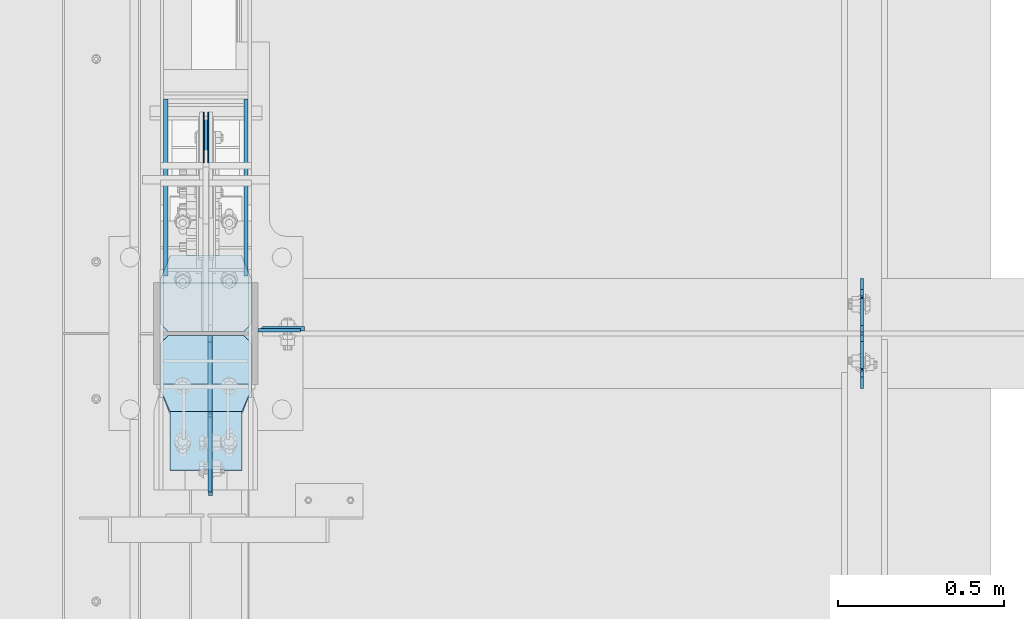
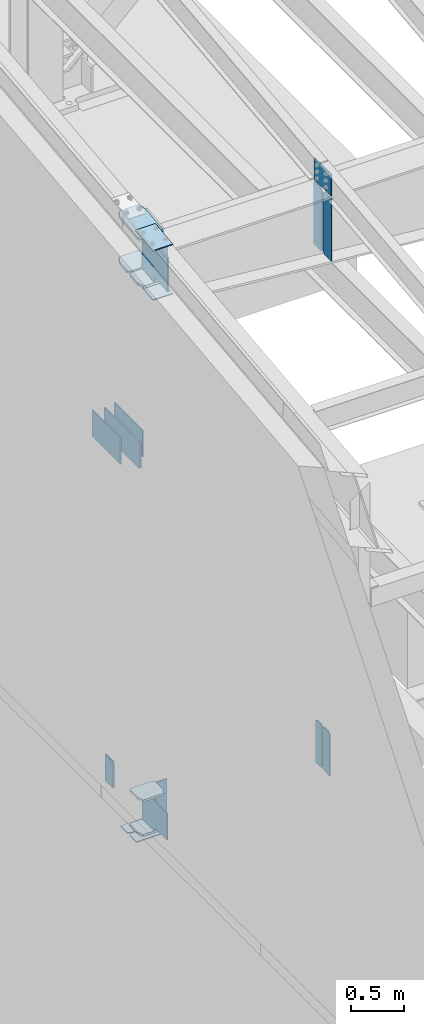
# One storey, part 990 of 1179: 23 plates, 4 elements without a shape of their own.
"""IFC2X3 building model written with IfcOpenShell, lengths in millimetres."""

from ifc_helpers import new_model, si_unit, frame, origin_with_axes, place, context, subcontext, project, spatial, faceted_brep, material, type_object, element, aggregate, save


model = new_model("IFC2X3")

# Units and contexts
model_context = context("Model", 3, precision=1e-05, world=origin_with_axes())
body_context = subcontext(model_context, "Body", "Model", "MODEL_VIEW")
ifc_project = project(units=[si_unit("LENGTHUNIT", "METRE", prefix="MILLI"), si_unit("AREAUNIT", "SQUARE_METRE"), si_unit("VOLUMEUNIT", "CUBIC_METRE"), si_unit("MASSUNIT", "GRAM", prefix="KILO"), si_unit("TIMEUNIT", "SECOND"), si_unit("PLANEANGLEUNIT", "RADIAN"), si_unit("SOLIDANGLEUNIT", "STERADIAN"), si_unit("THERMODYNAMICTEMPERATUREUNIT", "DEGREE_CELSIUS"), si_unit("LUMINOUSINTENSITYUNIT", "LUMEN")], contexts=[model_context])

# Site, building, storey
site_placement = place(None, origin_with_axes())
site = spatial("IfcSite", under=ifc_project, at=site_placement, CompositionType="ELEMENT")
building_placement = place(site_placement, origin_with_axes())
building = spatial("IfcBuilding", under=site, at=building_placement, Name="Undefined", CompositionType="ELEMENT")
storey_placement = place(building_placement, origin_with_axes())
storey = spatial("IfcBuildingStorey", under=building, at=storey_placement, Name="Undefined", CompositionType="ELEMENT", Elevation=0.0)

# Assembly, plate
assembly_1_placement = place(storey_placement, origin_with_axes())
assembly_1 = element("IfcElementAssembly", 1, at=assembly_1_placement, inside=storey, Name="COLUMN", AssemblyPlace="NOTDEFINED", PredefinedType="RIGID_FRAME")
ifc_material_1 = material(Name="STEEL/A36")
plate_type_1 = type_object("IfcPlateType", PredefinedType="NOTDEFINED")
plate_1_placement = place(assembly_1_placement, frame((588.962500000001, 11490.325, 4064.0), z_axis=(1.0, 0.0, 0.0), x_axis=(0.0, 0.0, -1.0)))
plate_1 = element("IfcPlate", 2, at=plate_1_placement, type_object=plate_type_1, material=ifc_material_1, Name="PLATE", context=body_context, shape_type="Brep", body=[
    faceted_brep([(0.0, -4.76249999999709, 0.0), (0.0, -4.76249999999709, 127.0), (0.0, 4.76249999999709, 127.0), (0.0, 4.76249999999709, 0.0), (381.0, -4.76249999999709, 127.0), (381.0, 4.76249999999709, 127.0), (381.0, -4.76249999999999, 8.66293703438714e-11), (381.0, 4.76249999999999, 8.66293703438714e-11)], [[[0, 1, 2, 3]], [[1, 4, 5, 2]], [[4, 6, 7, 5]], [[6, 0, 3, 7]], [[5, 7, 3, 2]], [[6, 4, 1, 0]]]),
])

# Assembly, plates
assembly_2_placement = place(storey_placement, origin_with_axes())
assembly_2 = element("IfcElementAssembly", 3, at=assembly_2_placement, inside=storey, Name="BEAM", AssemblyPlace="NOTDEFINED", PredefinedType="RIGID_FRAME")
plate_2_placement = place(assembly_2_placement, frame((2405.06192754092, 11476.0374998857, 3586.1625), z_axis=(0.0, 0.0, 1.0), x_axis=(0.0, -1.0, 0.0)))
plate_2 = element("IfcPlate", 4, at=plate_2_placement, type_object=plate_type_1, material=ifc_material_1, Name="PLATE", context=body_context, shape_type="Brep", body=[
    faceted_brep([(100.012500000004, -4.76250000000073, 498.475), (100.012499999999, -4.76249999999982, 496.887499809265), (100.012499999999, 4.76249999999982, 496.887499809265), (100.012500000004, 4.76250000000073, 498.475), (100.979229922586, -4.76249999999982, 492.027420291219), (100.979229922586, 4.76249999999982, 492.027420291219), (103.732243823064, -4.76249999999982, 487.907243823066), (103.732243823064, 4.76249999999982, 487.907243823066), (107.852420291218, -4.76249999999982, 485.154229922588), (107.852420291218, 4.76249999999982, 485.154229922588), (112.712499809264, -4.76249999999982, 484.1875), (112.712499809264, 4.76249999999982, 484.1875), (127.000006866454, -4.76249999999982, 484.1875), (127.000004873051, 4.76249999999982, 484.1875), (0.0, -4.76250000000073, 479.425006866455), (19.0499992370605, -4.76250000000073, 498.475006103516), (19.0499992370605, 4.76250000000073, 498.475006103516), (0.0, 4.76250000000073, 479.425006866455), (0.0, -4.76250000000073, 19.0499992370605), (0.0, 4.76250000000073, 19.0499992370605), (19.0499992370605, -4.76250000000073, 0.0), (19.0499992370605, 4.76250000000073, 0.0), (127.0, -4.76250000000073, 0.0), (127.0, 4.76250000000073, 0.0)], [[[0, 1, 2, 3]], [[4, 5, 2, 1]], [[6, 7, 5, 4]], [[8, 9, 7, 6]], [[10, 11, 9, 8]], [[12, 13, 11, 10]], [[14, 15, 16, 17]], [[18, 14, 17, 19]], [[20, 18, 19, 21]], [[22, 20, 21, 23]], [[8, 6, 4, 1, 0, 15, 14, 18, 20, 22, 12, 10]], [[16, 15, 0, 3]], [[23, 21, 19, 17, 16, 3, 2, 5, 7, 9, 11, 13]], [[22, 23, 13, 12]]]),
])
plate_3_placement = place(assembly_2_placement, frame((2405.06185359955, 11485.5625, 3586.1625), z_axis=(0.0, 0.0, 1.0), x_axis=(0.0, 1.0, 0.0)))
plate_3 = element("IfcPlate", 5, at=plate_3_placement, type_object=plate_type_1, material=ifc_material_1, Name="PLATE", context=body_context, shape_type="Brep", body=[
    faceted_brep([(100.012500000004, -4.76250000000073, 498.475), (100.012499999999, -4.76249999999982, 496.887499809265), (100.012499999999, 4.76249999999982, 496.887499809265), (100.012500000004, 4.76250000000073, 498.475), (100.979229922586, -4.76249999999982, 492.027420291219), (100.979229922586, 4.76249999999982, 492.027420291219), (103.732243823064, -4.76249999999982, 487.907243823066), (103.732243823064, 4.76249999999982, 487.907243823066), (107.852420291218, -4.76249999999982, 485.154229922588), (107.852420291218, 4.76249999999982, 485.154229922588), (112.712499809264, -4.76249999999982, 484.1875), (112.712499809264, 4.76249999999982, 484.1875), (127.000006866454, -4.76249999999982, 484.1875), (127.000004873051, 4.76249999999982, 484.1875), (0.0, -4.76250000000073, 479.425006866455), (19.0499992370605, -4.76250000000073, 498.475006103516), (19.0499992370605, 4.76250000000073, 498.475006103516), (0.0, 4.76250000000073, 479.425006866455), (0.0, -4.76250000000073, 19.0499992370605), (0.0, 4.76250000000073, 19.0499992370605), (19.0499992370605, -4.76250000000073, 0.0), (19.0499992370605, 4.76250000000073, 0.0), (127.0, -4.76250000000073, 0.0), (127.0, 4.76250000000073, 0.0)], [[[0, 1, 2, 3]], [[4, 5, 2, 1]], [[6, 7, 5, 4]], [[8, 9, 7, 6]], [[10, 11, 9, 8]], [[12, 13, 11, 10]], [[14, 15, 16, 17]], [[18, 14, 17, 19]], [[20, 18, 19, 21]], [[22, 20, 21, 23]], [[8, 6, 4, 1, 0, 15, 14, 18, 20, 22, 12, 10]], [[16, 15, 0, 3]], [[23, 21, 19, 17, 16, 3, 2, 5, 7, 9, 11, 13]], [[22, 23, 13, 12]]]),
])
aggregate(assembly_2, [plate_2, plate_3])

assembly_3_placement = place(storey_placement, origin_with_axes())
assembly_3 = element("IfcElementAssembly", 6, at=assembly_3_placement, inside=storey, Name="RAFTER BEAM", AssemblyPlace="NOTDEFINED", PredefinedType="RIGID_FRAME")
plate_type_2 = type_object("IfcPlateType", PredefinedType="NOTDEFINED")
plate_4_placement = place(assembly_3_placement, frame((2405.0625, 11645.9093353251, 10228.28385672), z_axis=(0.0, 0.0, -1.0), x_axis=(0.0, -1.0, 0.0)))
plate_4 = element("IfcPlate", 7, at=plate_4_placement, type_object=plate_type_2, material=ifc_material_1, Name="PLATE", context=body_context, shape_type="Brep", body=[
    faceted_brep([(0.0, -4.76249999999709, 0.0), (-1.6992817108985e-06, -4.76249999999982, 719.900724495752), (-1.6992817108985e-06, 4.76249999999982, 719.900724495752), (0.0, 4.76249999999709, 0.0), (131.762498682183, -4.76249999999982, 719.900724815363), (131.762498682183, 4.76249999999982, 719.900724815363), (157.162498360671, -4.76249999999982, 694.500725258442), (157.162498360671, 4.76249999999982, 694.500725258442), (157.162499942613, -4.76250000000073, 25.3999996182793), (157.162499942613, 4.76250000000073, 25.3999996182793), (131.762500381465, -4.76250000000073, -2.09183781407773e-10), (131.762500381465, 4.76250000000073, -2.09183781407773e-10)], [[[0, 1, 2, 3]], [[1, 4, 5, 2]], [[4, 6, 7, 5]], [[6, 8, 9, 7]], [[8, 10, 11, 9]], [[10, 0, 3, 11]], [[5, 7, 9, 11, 3, 2]], [[10, 8, 6, 4, 1, 0]]]),
])
plate_5_placement = place(assembly_3_placement, frame((2405.0625, 11315.7093353614, 10228.28385672), z_axis=(0.0, 0.0, -1.0), x_axis=(0.0, 1.0, 0.0)))
plate_5 = element("IfcPlate", 8, at=plate_5_placement, type_object=plate_type_2, material=ifc_material_1, Name="PLATE", context=body_context, shape_type="Brep", body=[
    faceted_brep([(0.0, -4.76249999999709, 0.0), (-1.6992817108985e-06, -4.76249999999982, 719.900724495752), (-1.6992817108985e-06, 4.76249999999982, 719.900724495752), (0.0, 4.76249999999709, 0.0), (131.762498682183, -4.76249999999982, 719.900724815363), (131.762498682183, 4.76249999999982, 719.900724815363), (157.162498360671, -4.76249999999982, 694.500725258442), (157.162498360671, 4.76249999999982, 694.500725258442), (157.162499942613, -4.76250000000073, 25.3999996182793), (157.162499942613, 4.76250000000073, 25.3999996182793), (131.762500381465, -4.76250000000073, -2.09183781407773e-10), (131.762500381465, 4.76250000000073, -2.09183781407773e-10)], [[[0, 1, 2, 3]], [[1, 4, 5, 2]], [[4, 6, 7, 5]], [[6, 8, 9, 7]], [[8, 10, 11, 9]], [[10, 0, 3, 11]], [[5, 7, 9, 11, 3, 2]], [[10, 8, 6, 4, 1, 0]]]),
])

# Plate
plate_type_3 = type_object("IfcPlateType", PredefinedType="NOTDEFINED")
plate_6_placement = place(assembly_1_placement, frame((588.962500000001, 11495.0968353614, 10213.99635672), z_axis=(0.0, 0.0, -1.0), x_axis=(1.0, 0.0, 0.0)))
plate_6 = element("IfcPlate", 9, at=plate_6_placement, type_object=plate_type_3, material=ifc_material_1, Name="PLATE", context=body_context, shape_type="Brep", body=[
    faceted_brep([(0.0, 6.34999999999854, 0.0), (12.7, -6.35000000000036, 0.0), (12.7, -6.35000000000036, 533.4), (0.0, 6.35000000000036, 533.4), (139.700000000001, -6.35000000000036, 533.4), (139.700000000001, 6.35000000000036, 533.4), (139.699999999997, -6.35000000000036, 0.0), (139.699999999997, 6.35000000000036, 0.0)], [[[0, 1, 2, 3]], [[4, 5, 3, 2]], [[4, 6, 7, 5]], [[7, 6, 1, 0]], [[5, 7, 0, 3]], [[6, 4, 2, 1]]]),
])

ifc_material_2 = material(Name="STEEL/A572-GR.50")
plate_type_4 = type_object("IfcPlateType", PredefinedType="NOTDEFINED")
plate_7_placement = place(assembly_1_placement, frame((431.799999999999, 12163.2501964861, 8013.7), z_axis=(0.0, 0.0, -1.0), x_axis=(0.0, -1.0, 0.0)))
plate_7 = element("IfcPlate", 10, at=plate_7_placement, type_object=plate_type_4, material=ifc_material_2, Name="PLATE", context=body_context, shape_type="Brep", body=[
    faceted_brep([(0.0, -9.52499999999964, 0.0), (0.0, -9.52499999999998, 304.799999999999), (0.0, 9.52499999999998, 304.799999999999), (0.0, 9.52499999999964, 0.0), (657.050197249024, -9.52499999999998, 304.799999999999), (657.050197249024, 9.52499999999998, 304.799999999999), (676.100196486084, -9.52499999999998, 285.750000762939), (676.100196486084, 9.52499999999998, 285.750000762939), (676.100196486084, -9.52499999999998, 19.0499992370605), (676.100196486084, 9.52499999999998, 19.0499992370605), (657.050197249024, -9.52499999999998, 0.0), (657.050197249024, 9.52499999999998, 0.0)], [[[0, 1, 2, 3]], [[1, 4, 5, 2]], [[4, 6, 7, 5]], [[6, 8, 9, 7]], [[8, 10, 11, 9]], [[10, 0, 3, 11]], [[5, 7, 9, 11, 3, 2]], [[10, 8, 6, 4, 1, 0]]]),
])

plate_type_5 = type_object("IfcPlateType", PredefinedType="NOTDEFINED")
plate_8_placement = place(assembly_1_placement, frame((295.274999999754, 11244.1139130949, 10503.1105351652), z_axis=(1.0, 0.0, 0.0), x_axis=(0.0, 0.993683229349742, 0.112221387039499)))
plate_8 = element("IfcPlate", 11, at=plate_8_placement, type_object=plate_type_5, material=ifc_material_2, Name="PLATE", context=body_context, shape_type="Brep", body=[
    faceted_brep([(404.009737741189, -14.2874999996602, 8.31619217933621e-11), (71.43750000002, -14.287499999984, 2.90469870378729e-11), (71.4375000000155, 14.2874999999949, 2.90469870378729e-11), (404.009737741166, 14.2875000003405, 8.31619217933621e-11), (477.034739267168, 14.2875000004005, 30.162500381568), (473.810043726306, -14.287499999602, 28.8305609300143), (477.034739268025, 14.2875000004024, 242.887499623284), (473.810043726306, -14.287499999602, 244.219439075195), (404.009737742264, 14.2875000003405, 273.05000000474), (404.00973774229, -14.2874999996602, 273.05000000474), (71.4375000016116, -14.2874999999858, 273.049999999798), (71.4375000016071, 14.2874999999967, 273.049999999798), (4.20644072178584, 14.2875000000058, 244.663552394444), (0.979329666730337, -14.2874999999967, 243.30099437618), (0.979329666730337, -14.2874999999967, 29.7490056281208), (4.20644072178584, 14.2875000000058, 28.3864476098539)], [[[0, 1, 2, 3]], [[0, 3, 4, 5]], [[5, 4, 6, 7]], [[8, 9, 7, 6]], [[10, 9, 8, 11]], [[10, 11, 12, 13]], [[1, 0, 5, 7, 9, 10, 13, 14]], [[2, 1, 14, 15]], [[11, 8, 6, 4, 3, 2, 15, 12]], [[14, 13, 12, 15]]]),
])

# Assembly, plates
assembly_4_placement = place(storey_placement, origin_with_axes())
assembly_4 = element("IfcElementAssembly", 12, at=assembly_4_placement, inside=storey, Name="BEAM", AssemblyPlace="NOTDEFINED", PredefinedType="RIGID_FRAME")
plate_type_6 = type_object("IfcPlateType", PredefinedType="NOTDEFINED")
plate_9_placement = place(assembly_4_placement, frame((438.943750000002, 12146.2984303375, 4044.95), z_axis=(0.0, 0.0, -1.0), x_axis=(0.0, -1.0, 0.0)))
plate_9 = element("IfcPlate", 13, at=plate_9_placement, type_object=plate_type_6, material=ifc_material_2, Name="PLATE", context=body_context, shape_type="Brep", body=[
    faceted_brep([(3.63797880709171e-12, -1.58750000000055, 1.81898940354586e-12), (-2.18278728425503e-11, -1.58750000000146, 304.8), (-2.18278728425503e-11, 1.58750000000146, 304.8), (-3.63797880709171e-12, 1.58750000000055, 0.0), (152.399999999994, -1.58750000000146, 304.8), (152.399999999994, 1.58750000000146, 304.8), (152.399999999994, -1.58750000000146, 0.0), (152.399999999994, 1.58750000000146, 0.0)], [[[0, 1, 2, 3]], [[1, 4, 5, 2]], [[4, 6, 7, 5]], [[6, 0, 3, 7]], [[5, 7, 3, 2]], [[6, 4, 1, 0]]]),
])
plate_10_placement = place(assembly_4_placement, frame((424.656250000002, 12146.2984303375, 4044.95), z_axis=(0.0, 0.0, -1.0), x_axis=(0.0, -1.0, 0.0)))
plate_10 = element("IfcPlate", 14, at=plate_10_placement, type_object=plate_type_6, material=ifc_material_2, Name="PLATE", context=body_context, shape_type="Brep", body=[
    faceted_brep([(3.63797880709171e-12, -1.58750000000055, 1.81898940354586e-12), (-2.18278728425503e-11, -1.58750000000146, 304.8), (-2.18278728425503e-11, 1.58750000000146, 304.8), (-3.63797880709171e-12, 1.58750000000055, 0.0), (152.399999999994, -1.58750000000146, 304.8), (152.399999999994, 1.58750000000146, 304.8), (152.399999999994, -1.58750000000146, 0.0), (152.399999999994, 1.58750000000146, 0.0)], [[[0, 1, 2, 3]], [[1, 4, 5, 2]], [[4, 6, 7, 5]], [[6, 0, 3, 7]], [[5, 7, 3, 2]], [[6, 4, 1, 0]]]),
])
aggregate(assembly_4, [plate_9, plate_10])

# Plate
plate_type_7 = type_object("IfcPlateType", PredefinedType="NOTDEFINED")
plate_11_placement = place(assembly_1_placement, frame((552.450000000001, 12185.4751974615, 8013.7), z_axis=(0.0, 0.0, -1.0), x_axis=(0.0, -1.0, 0.0)))
plate_11 = element("IfcPlate", 15, at=plate_11_placement, type_object=plate_type_7, material=ifc_material_2, Name="PLATE", context=body_context, shape_type="Brep", body=[
    faceted_brep([(0.0, -6.34999999999854, 0.0), (0.0, -6.34999999999854, 304.799999999999), (0.0, 6.34999999999854, 304.799999999999), (0.0, 6.34999999999854, 0.0), (531.637696486086, -6.34999999999854, 304.799999999999), (531.637696486086, 6.34999999999854, 304.799999999999), (531.637696486086, -6.34999999999854, 0.0), (531.637696486086, 6.34999999999854, 0.0)], [[[0, 1, 2, 3]], [[1, 4, 5, 2]], [[4, 6, 7, 5]], [[6, 0, 3, 7]], [[5, 7, 3, 2]], [[6, 4, 1, 0]]]),
])

plate_12_placement = place(assembly_1_placement, frame((311.150000000001, 12185.4751974615, 8013.7), z_axis=(0.0, 0.0, -1.0), x_axis=(0.0, -1.0, 0.0)))
plate_12 = element("IfcPlate", 16, at=plate_12_placement, type_object=plate_type_7, material=ifc_material_2, Name="PLATE", context=body_context, shape_type="Brep", body=[
    faceted_brep([(0.0, -6.34999999999854, 0.0), (0.0, -6.34999999999854, 304.799999999999), (0.0, 6.34999999999854, 304.799999999999), (0.0, 6.34999999999854, 0.0), (531.637696486086, -6.34999999999854, 304.799999999999), (531.637696486086, 6.34999999999854, 304.799999999999), (531.637696486086, -6.34999999999854, 0.0), (531.637696486086, 6.34999999999854, 0.0)], [[[0, 1, 2, 3]], [[1, 4, 5, 2]], [[4, 6, 7, 5]], [[6, 0, 3, 7]], [[5, 7, 3, 2]], [[6, 4, 1, 0]]]),
])

plate_type_8 = type_object("IfcPlateType", PredefinedType="NOTDEFINED")
plate_13_placement = place(assembly_1_placement, frame((295.275000000005, 11245.85, 3694.1125), z_axis=(1.0, 0.0, 0.0), x_axis=(0.0, 1.0, 0.0)))
plate_13 = element("IfcPlate", 17, at=plate_13_placement, type_object=plate_type_8, material=ifc_material_2, Name="PLATE", context=body_context, shape_type="Brep", body=[
    faceted_brep([(0.0, -11.1125000000002, 247.650000381473), (63.5, -11.1125000000002, 273.050000000003), (63.5, 11.1125000000002, 273.050000000003), (0.0, 11.1125000000002, 247.650000381473), (63.5, -11.1125000000002, 0.0), (0.0, -11.1125000000002, 25.3999996185303), (0.0, 11.1125000000002, 25.3999996185303), (63.5, 11.1125000000002, 0.0), (206.374999618529, -11.1125000000002, 0.0), (206.374999618529, 11.1125000000002, 0.0), (228.599999999999, -11.1125000000002, 22.2250003814697), (228.599999999999, 11.1125000000002, 22.2250003814697), (228.599999999999, -11.1125000000002, 250.824999618533), (228.599999999999, 11.1125000000002, 250.824999618533), (206.374999618529, -11.1125000000002, 273.050000000003), (206.374999618529, 11.1125000000002, 273.050000000003)], [[[0, 1, 2, 3]], [[4, 5, 6, 7]], [[8, 4, 7, 9]], [[10, 8, 9, 11]], [[12, 10, 11, 13]], [[14, 12, 13, 15]], [[4, 8, 10, 12, 14, 1, 0, 5]], [[5, 0, 3, 6]], [[2, 15, 13, 11, 9, 7, 6, 3]], [[1, 14, 15, 2]]]),
])

plate_14_placement = place(assembly_1_placement, frame((295.275000000005, 11245.85, 4090.9875), z_axis=(1.0, 0.0, 0.0), x_axis=(0.0, 1.0, 0.0)))
plate_14 = element("IfcPlate", 18, at=plate_14_placement, type_object=plate_type_8, material=ifc_material_2, Name="PLATE", context=body_context, shape_type="Brep", body=[
    faceted_brep([(0.0, -11.1125000000002, 247.650000381473), (63.5, -11.1125000000002, 273.050000000003), (63.5, 11.1125000000002, 273.050000000003), (0.0, 11.1125000000002, 247.650000381473), (63.5, -11.1125000000002, 0.0), (0.0, -11.1125000000002, 25.3999996185303), (0.0, 11.1125000000002, 25.3999996185303), (63.5, 11.1125000000002, 0.0), (206.374999618529, -11.1125000000002, 0.0), (206.374999618529, 11.1125000000002, 0.0), (228.599999999999, -11.1125000000002, 22.2250003814697), (228.599999999999, 11.1125000000002, 22.2250003814697), (228.599999999999, -11.1125000000002, 250.824999618533), (228.599999999999, 11.1125000000002, 250.824999618533), (206.374999618529, -11.1125000000002, 273.050000000003), (206.374999618529, 11.1125000000002, 273.050000000003)], [[[0, 1, 2, 3]], [[4, 5, 6, 7]], [[8, 4, 7, 9]], [[10, 8, 9, 11]], [[12, 10, 11, 13]], [[14, 12, 13, 15]], [[4, 8, 10, 12, 14, 1, 0, 5]], [[5, 0, 3, 6]], [[2, 15, 13, 11, 9, 7, 6, 3]], [[1, 14, 15, 2]]]),
])

plate_type_9 = type_object("IfcPlateType", PredefinedType="NOTDEFINED")
plate_15_placement = place(assembly_1_placement, frame((568.325000000002, 11474.45, 3575.05), z_axis=(-1.0, 0.0, 0.0), x_axis=(0.0, -1.0, 0.0)))
plate_15 = element("IfcPlate", 19, at=plate_15_placement, type_object=plate_type_9, material=ifc_material_1, Name="PLATE", context=body_context, shape_type="Brep", body=[
    faceted_brep([(0.0, -6.34999999999854, 22.2250003814697), (0.0, -6.35000000000036, 250.82499961853), (0.0, 6.35000000000036, 250.82499961853), (0.0, 6.34999999999854, 22.2250003814697), (22.2250003814697, -6.35000000000036, 273.05), (22.2250003814697, 6.35000000000036, 273.05), (146.050003051758, -6.35000000000036, 273.049987792969), (146.050003051758, 6.35000000000036, 273.049987792969), (146.050003051758, -6.35000000000036, 0.0), (146.050003051758, 6.35000000000036, 0.0), (22.2250003814697, -6.34999999999854, 0.0), (22.2250003814697, 6.34999999999854, 0.0)], [[[0, 1, 2, 3]], [[1, 4, 5, 2]], [[4, 6, 7, 5]], [[6, 8, 9, 7]], [[8, 10, 11, 9]], [[10, 0, 3, 11]], [[5, 7, 9, 11, 3, 2]], [[10, 8, 6, 4, 1, 0]]]),
])

plate_16_placement = place(assembly_1_placement, frame((568.325000000002, 11633.2, 3575.05), z_axis=(-1.0, 0.0, 0.0), x_axis=(0.0, -1.0, 0.0)))
plate_16 = element("IfcPlate", 20, at=plate_16_placement, type_object=plate_type_9, material=ifc_material_1, Name="PLATE", context=body_context, shape_type="Brep", body=[
    faceted_brep([(0.0, -6.34999999999854, 0.0), (0.0, -6.34999999999991, 273.05), (0.0, 6.34999999999991, 273.05), (0.0, 6.34999999999854, 0.0), (123.824999618599, -6.34999999999991, 273.05), (123.824999618599, 6.34999999999991, 273.05), (146.050000000068, -6.34999999999991, 250.82499961853), (146.050000000068, 6.34999999999991, 250.82499961853), (146.050000000068, -6.34999999999991, 22.2250003814697), (146.050000000068, 6.34999999999991, 22.2250003814697), (123.824999618599, -6.34999999999991, 0.0), (123.824999618599, 6.34999999999991, 0.0)], [[[0, 1, 2, 3]], [[1, 4, 5, 2]], [[4, 6, 7, 5]], [[6, 8, 9, 7]], [[8, 10, 11, 9]], [[10, 0, 3, 11]], [[5, 7, 9, 11, 3, 2]], [[10, 8, 6, 4, 1, 0]]]),
])

plate_type_10 = type_object("IfcPlateType", PredefinedType="NOTDEFINED")
plate_17_placement = place(assembly_1_placement, frame((323.850003068444, 11069.8882512744, 10504.1625635756), z_axis=(1.0, 0.0, 0.0), x_axis=(0.0, 0.993676146336441, 0.112284087038017)))
plate_17 = element("IfcPlate", 21, at=plate_17_placement, type_object=plate_type_10, material=ifc_material_2, Name="PLATE", context=body_context, shape_type="Brep", body=[
    faceted_brep([(0.0, -6.34999999999854, 0.0), (0.0, -6.350000000004, 215.899993896484), (0.0, 6.35000000000582, 215.899993896484), (0.0, 6.34999999999854, 0.0), (330.200000001782, -6.34999999994034, 215.899993896483), (330.200000001782, 6.35000000006767, 215.899993896483), (330.200000001782, -6.34999999994034, -1.47792889038101e-12), (330.200000001782, 6.35000000006767, -1.47792889038101e-12)], [[[0, 1, 2, 3]], [[1, 4, 5, 2]], [[4, 6, 7, 5]], [[6, 0, 3, 7]], [[5, 7, 3, 2]], [[6, 4, 1, 0]]]),
])

plate_18_placement = place(assembly_1_placement, frame((323.850003041494, 11070.5392709455, 9938.6753306312), z_axis=(1.0, 0.0, 0.0), x_axis=(0.0, 0.993676146336441, 0.112284087038017)))
plate_18 = element("IfcPlate", 22, at=plate_18_placement, type_object=plate_type_10, material=ifc_material_2, Name="PLATE", context=body_context, shape_type="Brep", body=[
    faceted_brep([(0.0, -6.34999999999854, 0.0), (0.0, -6.350000000004, 215.899993896484), (0.0, 6.35000000000582, 215.899993896484), (0.0, 6.34999999999854, 0.0), (330.200000001782, -6.34999999994034, 215.899993896483), (330.200000001782, 6.35000000006767, 215.899993896483), (330.200000001782, -6.34999999994034, -1.47792889038101e-12), (330.200000001782, 6.35000000006767, -1.47792889038101e-12)], [[[0, 1, 2, 3]], [[1, 4, 5, 2]], [[4, 6, 7, 5]], [[6, 0, 3, 7]], [[5, 7, 3, 2]], [[6, 4, 1, 0]]]),
])

plate_type_11 = type_object("IfcPlateType", PredefinedType="NOTDEFINED")
plate_19_placement = place(assembly_1_placement, frame((295.275000000052, 11244.1139131727, 9978.9669475639), z_axis=(1.0, 0.0, 0.0), x_axis=(0.0, 0.993676146336441, 0.112284087038017)))
plate_19 = element("IfcPlate", 23, at=plate_19_placement, type_object=plate_type_11, material=ifc_material_2, Name="PLATE", context=body_context, shape_type="Brep", body=[
    faceted_brep([(207.962499617965, -14.2875000000749, 8.87325768417213e-11), (71.43750000002, -14.287499999984, 2.90469870378729e-11), (71.4375000000155, 14.2874999999949, 2.90469870378729e-11), (207.962499617975, 14.2874999999094, 8.87325768417213e-11), (230.187499999511, -14.287500000084, 22.225000381568), (230.187499999523, 14.2874999999003, 22.225000381568), (230.187500000431, -14.2875000000822, 250.824999623284), (230.187500000442, 14.2874999998985, 250.824999623284), (207.962499619063, -14.2875000000731, 273.050000004745), (207.962499619074, 14.2874999999112, 273.050000004745), (71.4375000016116, -14.2874999999858, 273.049999999798), (71.4375000016071, 14.2874999999967, 273.049999999798), (4.20737223302058, 14.2874999999931, 244.663945699182), (0.978435120117865, -14.2874999999894, 243.300616678719), (0.978435120117865, -14.2874999999894, 29.7493833255772), (4.20737223302058, 14.2874999999931, 28.3860543051127)], [[[0, 1, 2, 3]], [[4, 0, 3, 5]], [[6, 4, 5, 7]], [[8, 6, 7, 9]], [[10, 8, 9, 11]], [[10, 11, 12, 13]], [[1, 0, 4, 6, 8, 10, 13, 14]], [[2, 1, 14, 15]], [[11, 9, 7, 5, 3, 2, 15, 12]], [[14, 13, 12, 15]]]),
])

plate_type_12 = type_object("IfcPlateType", PredefinedType="NOTDEFINED")
plate_20_placement = place(assembly_1_placement, frame((568.325000000002, 11719.0635477105, 10032.6356265712), z_axis=(-1.0, 0.0, 0.0), x_axis=(0.0, -0.993676146336441, -0.112284087038017)))
plate_20 = element("IfcPlate", 24, at=plate_20_placement, type_object=plate_type_12, material=ifc_material_2, Name="PLATE", context=body_context, shape_type="Brep", body=[
    faceted_brep([(209.549999618157, -14.287499999904, 0.0), (73.0250015258425, -14.2874999999603, 0.0), (73.0250015258298, 14.2875000000258, 0.0), (209.549999618144, 14.2875000000804, 0.0), (231.774999999612, -14.2874999998949, 22.2250003814697), (231.774999999603, 14.2875000000895, 22.2250003814697), (231.774999999612, -14.2874999998949, 250.824999618533), (231.774999999603, 14.2875000000895, 250.824999618533), (209.549999618157, -14.287499999904, 273.050000000002), (209.549999618144, 14.2875000000804, 273.050000000002), (73.0250015258425, -14.2874999999603, 273.049999999998), (73.0250015258298, 14.2875000000258, 273.049999999998), (4.15974163581814, -14.2874999999876, 244.605653758279), (4.15974163581814, -14.2874999999876, 28.4443462417166), (0.930804522917242, 14.2874999999949, 29.7780376469105), (0.930804522917242, 14.2874999999949, 243.271962353085)], [[[0, 1, 2, 3]], [[4, 0, 3, 5]], [[6, 4, 5, 7]], [[8, 6, 7, 9]], [[10, 8, 9, 11]], [[1, 0, 4, 6, 8, 10, 12, 13]], [[2, 1, 13, 14]], [[11, 9, 7, 5, 3, 2, 14, 15]], [[10, 11, 15, 12]], [[14, 13, 12, 15]]]),
])

plate_type_13 = type_object("IfcPlateType", PredefinedType="NOTDEFINED")
plate_21_placement = place(assembly_1_placement, frame((445.293750000002, 11474.4499999807, 10038.0276509356), z_axis=(0.0, -0.743858433013958, 0.668337214012522), x_axis=(0.0, -0.668337214012522, -0.743858433013957)))
plate_21 = element("IfcPlate", 25, at=plate_21_placement, type_object=plate_type_13, material=ifc_material_2, Name="PLATE", context=body_context, shape_type="Brep", body=[
    faceted_brep([(-340.292620779428, -6.35000000000002, 331.182640750629), (-340.36472431031, 6.35000000000002, 331.263802238369), (-340.417795237816, 6.35000000000002, 305.856424769073), (-340.417795237816, -6.35000000000002, 305.856424769073), (28.5035613092805, -6.35000000000002, -1.04591890703887e-11), (0.0, -6.34999999999854, 0.0), (0.0, 6.34999999999854, 0.0), (28.5035613092805, 6.35000000000002, -1.04591890703887e-11), (185.535041792471, -6.35000000000002, 139.488379402524), (185.535041792471, 6.35000000000002, 139.488379402524), (150.391206739107, -6.35000000000002, 171.064189752232), (150.391206739107, 6.35000000000002, 171.064189752232), (145.102749755571, -6.35000000000002, 177.732630246504), (145.102749755571, 6.35000000000002, 177.732630246504), (142.314026896069, -6.35000000000002, 185.773706089029), (142.314026896069, 6.35000000000002, 185.773706089029), (142.338144349787, -6.35000000000002, 194.28459877081), (142.338144349787, 6.35000000000002, 194.28459877081), (145.172394309466, -6.35000000000002, 202.30974070466), (145.172394309466, 6.35000000000002, 202.30974070466), (150.498558992693, -6.35000000000002, 208.948102374491), (150.498558992693, 6.35000000000002, 208.948102374491), (319.572465694362, -6.35000000000002, 359.133576332748), (319.572465694362, 6.35000000000002, 359.133576332748), (24.8516291671876, -6.35000000000002, 623.932487042394), (24.8516291671876, 6.35000000000002, 623.932487042394), (-148.513946545472, -6.35000000000002, 469.934796538949), (-148.513946545472, 6.35000000000002, 469.934796538949), (-156.393362644572, -6.35000000000002, 465.168486686387), (-156.393362644572, 6.35000000000002, 465.168486686387), (-165.454335371476, -6.35000000000002, 463.524807607098), (-165.454335371476, 6.35000000000002, 463.524807607098), (-174.505847216309, -6.35000000000002, 465.219812325748), (-174.505847216309, 6.35000000000002, 465.219812325748), (-182.358124252696, -6.35000000000002, 470.030701330617), (-182.358124252696, 6.35000000000002, 470.030701330617), (-183.256630002494, 6.35000000000002, 470.837985086379), (-183.256630002494, -6.35000000000002, 470.837985086379)], [[[0, 1, 2, 3]], [[4, 5, 6, 7]], [[8, 4, 7, 9]], [[10, 8, 9, 11]], [[12, 10, 11, 13]], [[14, 12, 13, 15]], [[16, 14, 15, 17]], [[18, 16, 17, 19]], [[20, 18, 19, 21]], [[22, 20, 21, 23]], [[24, 22, 23, 25]], [[26, 24, 25, 27]], [[28, 26, 27, 29]], [[30, 28, 29, 31]], [[32, 30, 31, 33]], [[34, 32, 33, 35]], [[34, 35, 36, 37]], [[5, 4, 8, 10, 12, 14, 16, 18, 20, 22, 24, 26, 28, 30, 32, 34, 37, 0, 3]], [[6, 5, 3, 2]], [[36, 35, 33, 31, 29, 27, 25, 23, 21, 19, 17, 15, 13, 11, 9, 7, 6, 2, 1]], [[37, 36, 1, 0]]]),
])

plate_type_14 = type_object("IfcPlateType", PredefinedType="NOTDEFINED")
plate_22_placement = place(assembly_3_placement, frame((2405.0625, 11639.5500004736, 10252.0963567619), z_axis=(0.0, -1.0, 0.0), x_axis=(0.0, 0.0, 1.0)))
plate_22 = element("IfcPlate", 26, at=plate_22_placement, type_object=plate_type_14, material=ifc_material_1, Name="PLATE", context=body_context, shape_type="Brep", body=[
    faceted_brep([(0.0, -4.76249999999709, 0.0), (8.00355337560177e-11, -4.7624999999889, 317.49999188591), (6.91215973347425e-11, 4.76250000001255, 317.49999188591), (0.0, 4.76249999999709, 0.0), (254.0, -4.76249999999982, 317.5), (254.0, 4.76249999999982, 317.5), (254.0, -4.76250000000073, 0.0), (254.0, 4.76250000000073, 0.0)], [[[0, 1, 2, 3]], [[1, 4, 5, 2]], [[4, 6, 7, 5]], [[6, 0, 3, 7]], [[5, 7, 3, 2]], [[6, 4, 1, 0]]]),
])

aggregate(assembly_3, [plate_4, plate_5, plate_22])

plate_type_15 = type_object("IfcPlateType", PredefinedType="NOTDEFINED")
plate_23_placement = place(assembly_1_placement, frame((443.706250000002, 11474.4499999564, 3724.275), z_axis=(0.0, -0.707106781186506, 0.707106781186589), x_axis=(0.0, -0.70710678118659, -0.707106781186505)))
plate_23 = element("IfcPlate", 27, at=plate_23_placement, type_object=plate_type_15, material=ifc_material_2, Name="PLATE", context=body_context, shape_type="Brep", body=[
    faceted_brep([(0.0, -6.34999999999854, 0.0), (-237.976787208419, -6.34999999999854, 237.976787208414), (-237.976787208419, 6.34999999999854, 237.976787208414), (0.0, 6.34999999999854, 0.0), (-237.976787208489, -6.34999999999854, 264.917555571561), (-237.976787208489, 6.34999999999854, 264.917555571561), (-89.8025612115634, -6.34999999999854, 413.09178156849), (-89.8025612115634, 6.34999999999854, 413.09178156849), (-87.5574986365136, -6.35000000000002, 410.846713673389), (-87.5574986365136, 6.35000000000002, 410.846713673389), (-79.3171439752477, -6.34999999999854, 405.340689467515), (-79.3171439752477, 6.34999999999854, 405.340689467515), (-69.5969849391658, -6.34999999999854, 403.407229622333), (-69.5969849391658, 6.34999999999854, 403.407229622333), (-59.8768259030876, -6.34999999999854, 405.340689467494), (-59.8768259030876, 6.34999999999854, 405.340689467494), (-51.6364729667966, -6.34999999999854, 410.84671726843), (-51.6364729667966, 6.34999999999854, 410.84671726843), (101.027881360342, -6.34999999999854, 563.511071595573), (101.027881360342, 6.34999999999854, 563.511071595573), (316.554028266077, -6.34999999999854, 347.984924689843), (316.554028266077, 6.34999999999854, 347.984924689843), (163.889673938938, -6.34999999999854, 195.320570362701), (163.889673938938, 6.34999999999854, 195.320570362701), (158.383646138001, -6.34999999999854, 187.080217426408), (158.383646138001, 6.34999999999854, 187.080217426408), (156.450186292839, -6.34999999999854, 177.360058390334), (156.450186292839, 6.34999999999854, 177.360058390334), (158.383646138027, -6.34999999999854, 167.639899354248), (158.383646138027, 6.34999999999854, 167.639899354248), (163.889673938986, -6.34999999999854, 159.399546417944), (163.889673938986, 6.34999999999854, 159.399546417944), (175.114994360907, -6.34999999999854, 148.174225997692), (175.114994360907, 6.34999999999854, 148.174225997692), (26.9407683631471, -6.34999999999854, -6.91215973347425e-11), (26.9407683631471, 6.34999999999854, -6.91215973347425e-11)], [[[0, 1, 2, 3]], [[1, 4, 5, 2]], [[4, 6, 7, 5]], [[6, 8, 9, 7]], [[8, 10, 11, 9]], [[10, 12, 13, 11]], [[12, 14, 15, 13]], [[14, 16, 17, 15]], [[16, 18, 19, 17]], [[18, 20, 21, 19]], [[20, 22, 23, 21]], [[22, 24, 25, 23]], [[24, 26, 27, 25]], [[26, 28, 29, 27]], [[28, 30, 31, 29]], [[30, 32, 33, 31]], [[32, 34, 35, 33]], [[34, 0, 3, 35]], [[5, 7, 9, 11, 13, 15, 17, 19, 21, 23, 25, 27, 29, 31, 33, 35, 3, 2]], [[34, 32, 30, 28, 26, 24, 22, 20, 18, 16, 14, 12, 10, 8, 6, 4, 1, 0]]]),
])

aggregate(assembly_1, [plate_7, plate_11, plate_12, plate_17, plate_8, plate_20, plate_18, plate_19, plate_21, plate_6, plate_13, plate_14, plate_23, plate_15, plate_16, plate_1])

save(model, "model.ifc")
